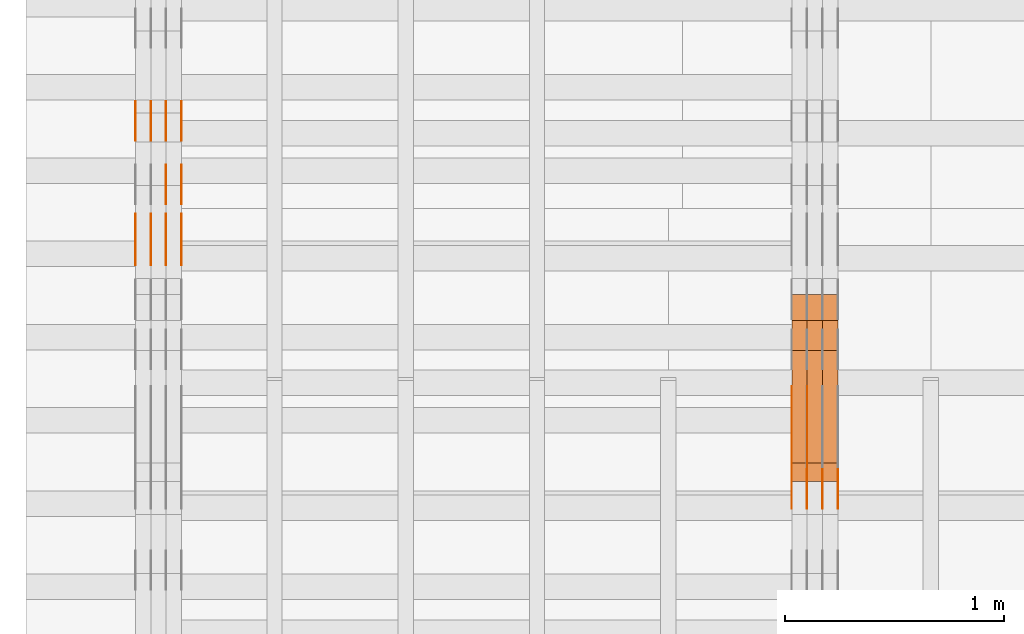
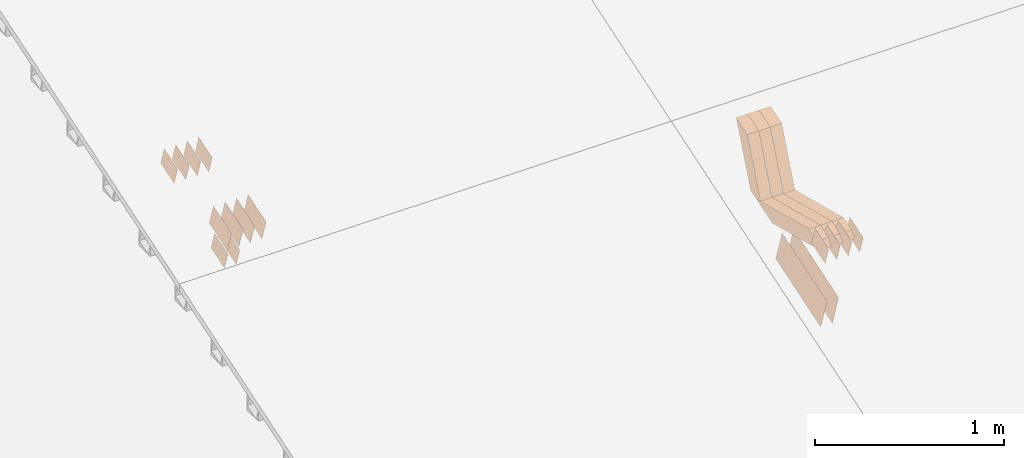
# One storey, part 46 of 385: 28 proxies.
"""IFC2X3 building model written with IfcOpenShell, lengths in millimetres."""

from ifc_helpers import new_model, entity, si_unit, converted_unit, derived_unit, direction, frame, origin, place, context, subcontext, project, spatial, polyline, outline, extrude, source, transform, mapped, material, type_object, type_shapes, element, save


model = new_model("IFC2X3")

# Units and contexts
model_context = context("Model", 3, precision=0.01, world=origin(), true_north=direction((6.12303176911189e-17, 1.0)))
body_context = subcontext(model_context, "Body", "Model", "MODEL_VIEW")
ifc_project = project(units=[si_unit("LENGTHUNIT", "METRE", prefix="MILLI"), si_unit("AREAUNIT", "SQUARE_METRE"), si_unit("VOLUMEUNIT", "CUBIC_METRE"), converted_unit("PLANEANGLEUNIT", "DEGREE", entity("IfcRatioMeasure", 0.0174532925199433), si_unit("PLANEANGLEUNIT", "RADIAN"), dimensions=[0, 0, 0, 0, 0, 0, 0]), si_unit("MASSUNIT", "GRAM", prefix="KILO"), derived_unit("MASSDENSITYUNIT", [(si_unit("MASSUNIT", "GRAM", prefix="KILO"), 1), (si_unit("LENGTHUNIT", "METRE"), -3)]), si_unit("TIMEUNIT", "SECOND"), si_unit("FREQUENCYUNIT", "HERTZ"), si_unit("THERMODYNAMICTEMPERATUREUNIT", "DEGREE_CELSIUS"), derived_unit("THERMALTRANSMITTANCEUNIT", [(si_unit("MASSUNIT", "GRAM", prefix="KILO"), 1), (si_unit("THERMODYNAMICTEMPERATUREUNIT", "KELVIN"), -1), (si_unit("TIMEUNIT", "SECOND"), -3)]), derived_unit("VOLUMETRICFLOWRATEUNIT", [(si_unit("LENGTHUNIT", "METRE"), 3), (si_unit("TIMEUNIT", "SECOND"), -1)]), si_unit("ELECTRICCURRENTUNIT", "AMPERE"), si_unit("ELECTRICVOLTAGEUNIT", "VOLT"), si_unit("POWERUNIT", "WATT"), si_unit("FORCEUNIT", "NEWTON", prefix="KILO"), si_unit("ILLUMINANCEUNIT", "LUX"), si_unit("LUMINOUSFLUXUNIT", "LUMEN"), si_unit("LUMINOUSINTENSITYUNIT", "CANDELA"), derived_unit("USERDEFINED", [(si_unit("MASSUNIT", "GRAM", prefix="KILO"), -1), (si_unit("LENGTHUNIT", "METRE"), -2), (si_unit("TIMEUNIT", "SECOND"), 3), (si_unit("LUMINOUSFLUXUNIT", "LUMEN"), 1)]), derived_unit("LINEARVELOCITYUNIT", [(si_unit("LENGTHUNIT", "METRE"), 1), (si_unit("TIMEUNIT", "SECOND"), -1)]), si_unit("PRESSUREUNIT", "PASCAL"), derived_unit("USERDEFINED", [(si_unit("LENGTHUNIT", "METRE"), -2), (si_unit("MASSUNIT", "GRAM", prefix="KILO"), 1), (si_unit("TIMEUNIT", "SECOND"), -2)])], contexts=[model_context])

# Site, building, storey
site_placement = place(None, origin())
site = spatial("IfcSite", under=ifc_project, at=site_placement, CompositionType="ELEMENT")
building_placement = place(site_placement, origin())
building = spatial("IfcBuilding", under=site, at=building_placement, CompositionType="ELEMENT")
storey_placement = place(building_placement, origin())
storey = spatial("IfcBuildingStorey", under=building, at=storey_placement, Name="Default", CompositionType="ELEMENT", Elevation=0.0)

# Proxies
ifc_material_1 = material(Name="IfcSurfaceStyle #73920")
building_element_proxy_type_1 = type_object("IfcBuildingElementProxyType", PredefinedType="NOTDEFINED", material=ifc_material_1)
shared_shape_1 = source(origin(), body_context, "Body", "SweptSolid", [
    extrude(outline(polyline([(-249.999749056184, -108.000229288163), (249.999396050782, -108.000229288163), (249.999749056184, 108.000229288163), (-249.999396050782, 108.000229288163), (-249.999749056184, -108.000229288163)])), frame((249.999841104007, 108.000229288163, 0.0), z_axis=(0.0, 0.0, 1.0), x_axis=(-1.0, 0.0, 0.0)), (0.0, 0.0, 1.0), 1.29999999999997),
])
type_shapes(building_element_proxy_type_1, [shared_shape_1])
proxy_1_placement = place(building_placement, frame((3246.29999999999, 7917.13457673635, 1720.66532252899), z_axis=(-1.0, 0.0, 0.0), x_axis=(0.0, 0.951056516295124, 0.309016994375039)))
element("IfcBuildingElementProxy", 1, at=proxy_1_placement, inside=storey, type_object=building_element_proxy_type_1, material=ifc_material_1, context=body_context, shape_type="MappedRepresentation", body=[
    mapped(shared_shape_1, transform((0.0, 0.0, 0.0), scale=1.0)),
])
ifc_material_2 = material(Name="IfcSurfaceStyle #73863")
building_element_proxy_type_2 = type_object("IfcBuildingElementProxyType", PredefinedType="NOTDEFINED", material=ifc_material_2)
shared_shape_2 = source(origin(), body_context, "Body", "SweptSolid", [
    extrude(outline(polyline([(-249.999749056184, -108.000229288163), (249.999396050782, -108.000229288163), (249.999749056184, 108.000229288163), (-249.999396050782, 108.000229288163), (-249.999749056184, -108.000229288163)])), frame((249.999841104007, 108.000229288163, 0.0), z_axis=(0.0, 0.0, 1.0), x_axis=(-1.0, 0.0, 0.0)), (0.0, 0.0, 1.0), 1.29999999999997),
])
type_shapes(building_element_proxy_type_2, [shared_shape_2])
proxy_2_placement = place(building_placement, frame((3175.0, 7917.13457673635, 1720.66532252899), z_axis=(-1.0, 0.0, 0.0), x_axis=(0.0, 0.951056516295124, 0.309016994375039)))
element("IfcBuildingElementProxy", 2, at=proxy_2_placement, inside=storey, type_object=building_element_proxy_type_2, material=ifc_material_2, context=body_context, shape_type="MappedRepresentation", body=[
    mapped(shared_shape_2, transform((0.0, 0.0, 0.0), scale=1.0)),
])
ifc_material_3 = material(Name="IfcSurfaceStyle #60468")
building_element_proxy_type_3 = type_object("IfcBuildingElementProxyType", PredefinedType="NOTDEFINED", material=ifc_material_3)
shared_shape_3 = source(origin(), body_context, "Body", "SweptSolid", [
    extrude(outline(polyline([(-74.9998754286253, -60.0000016373506), (74.9998605591091, -60.0000016373506), (74.9998754286234, 60.0000016373506), (-74.9998605591072, 60.0000016373506), (-74.9998754286253, -60.0000016373506)])), frame((75.0007355357002, 60.0002637031812, 0.0), z_axis=(0.0, 0.0, 1.0), x_axis=(-1.0, 0.0, 0.0)), (0.0, 0.0, 1.0), 1.3),
])
type_shapes(building_element_proxy_type_3, [shared_shape_3])
proxy_3_placement = place(building_placement, frame((3386.29999999999, 7899.79204652808, 2069.58672486412), z_axis=(-1.0, 0.0, 0.0), x_axis=(0.0, 0.951056516295154, 0.309016994374948)))
element("IfcBuildingElementProxy", 3, at=proxy_3_placement, inside=storey, type_object=building_element_proxy_type_3, material=ifc_material_3, context=body_context, shape_type="MappedRepresentation", body=[
    mapped(shared_shape_3, transform((0.0, 0.0, 0.0), scale=1.0)),
])
ifc_material_4 = material(Name="IfcSurfaceStyle #60411")
building_element_proxy_type_4 = type_object("IfcBuildingElementProxyType", PredefinedType="NOTDEFINED", material=ifc_material_4)
shared_shape_4 = source(origin(), body_context, "Body", "SweptSolid", [
    extrude(outline(polyline([(-74.9998754286253, -60.0000016373506), (74.9998605591091, -60.0000016373506), (74.9998754286234, 60.0000016373506), (-74.9998605591072, 60.0000016373506), (-74.9998754286253, -60.0000016373506)])), frame((75.0007355357002, 60.0002637031812, 0.0), z_axis=(0.0, 0.0, 1.0), x_axis=(-1.0, 0.0, 0.0)), (0.0, 0.0, 1.0), 1.3),
])
type_shapes(building_element_proxy_type_4, [shared_shape_4])
proxy_4_placement = place(building_placement, frame((3315.0, 7899.79204652808, 2069.58672486412), z_axis=(-1.0, 0.0, 0.0), x_axis=(0.0, 0.951056516295154, 0.309016994374948)))
element("IfcBuildingElementProxy", 4, at=proxy_4_placement, inside=storey, type_object=building_element_proxy_type_4, material=ifc_material_4, context=body_context, shape_type="MappedRepresentation", body=[
    mapped(shared_shape_4, transform((0.0, 0.0, 0.0), scale=1.0)),
])
ifc_material_5 = material(Name="IfcSurfaceStyle #60354")
building_element_proxy_type_5 = type_object("IfcBuildingElementProxyType", PredefinedType="NOTDEFINED", material=ifc_material_5)
shared_shape_5 = source(origin(), body_context, "Body", "SweptSolid", [
    extrude(outline(polyline([(-74.9998754286253, -60.0000016373506), (74.9998605591091, -60.0000016373506), (74.9998754286234, 60.0000016373506), (-74.9998605591072, 60.0000016373506), (-74.9998754286253, -60.0000016373506)])), frame((75.0007355357002, 60.0002637031812, 0.0), z_axis=(0.0, 0.0, 1.0), x_axis=(-1.0, 0.0, 0.0)), (0.0, 0.0, 1.0), 1.3),
])
type_shapes(building_element_proxy_type_5, [shared_shape_5])
proxy_5_placement = place(building_placement, frame((3316.29999999999, 7899.79204652808, 2069.58672486412), z_axis=(-1.0, 0.0, 0.0), x_axis=(0.0, 0.951056516295154, 0.309016994374948)))
element("IfcBuildingElementProxy", 5, at=proxy_5_placement, inside=storey, type_object=building_element_proxy_type_5, material=ifc_material_5, context=body_context, shape_type="MappedRepresentation", body=[
    mapped(shared_shape_5, transform((0.0, 0.0, 0.0), scale=1.0)),
])
ifc_material_6 = material(Name="IfcSurfaceStyle #60297")
building_element_proxy_type_6 = type_object("IfcBuildingElementProxyType", PredefinedType="NOTDEFINED", material=ifc_material_6)
shared_shape_6 = source(origin(), body_context, "Body", "SweptSolid", [
    extrude(outline(polyline([(-74.9998754286253, -60.0000016373506), (74.9998605591091, -60.0000016373506), (74.9998754286234, 60.0000016373506), (-74.9998605591072, 60.0000016373506), (-74.9998754286253, -60.0000016373506)])), frame((75.0007355357002, 60.0002637031812, 0.0), z_axis=(0.0, 0.0, 1.0), x_axis=(-1.0, 0.0, 0.0)), (0.0, 0.0, 1.0), 1.29999999999999),
])
type_shapes(building_element_proxy_type_6, [shared_shape_6])
proxy_6_placement = place(building_placement, frame((3245.0, 7899.79204652808, 2069.58672486412), z_axis=(-1.0, 0.0, 0.0), x_axis=(0.0, 0.951056516295154, 0.309016994374948)))
element("IfcBuildingElementProxy", 6, at=proxy_6_placement, inside=storey, type_object=building_element_proxy_type_6, material=ifc_material_6, context=body_context, shape_type="MappedRepresentation", body=[
    mapped(shared_shape_6, transform((0.0, 0.0, 0.0), scale=1.0)),
])
ifc_material_7 = material(Name="IfcSurfaceStyle #60240")
building_element_proxy_type_7 = type_object("IfcBuildingElementProxyType", PredefinedType="NOTDEFINED", material=ifc_material_7)
shared_shape_7 = source(origin(), body_context, "Body", "SweptSolid", [
    extrude(outline(polyline([(-74.9998754286253, -60.0000016373506), (74.9998605591091, -60.0000016373506), (74.9998754286234, 60.0000016373506), (-74.9998605591072, 60.0000016373506), (-74.9998754286253, -60.0000016373506)])), frame((75.0007355357002, 60.0002637031812, 0.0), z_axis=(0.0, 0.0, 1.0), x_axis=(-1.0, 0.0, 0.0)), (0.0, 0.0, 1.0), 1.29999999999999),
])
type_shapes(building_element_proxy_type_7, [shared_shape_7])
proxy_7_placement = place(building_placement, frame((3246.29999999999, 7899.79204652808, 2069.58672486412), z_axis=(-1.0, 0.0, 0.0), x_axis=(0.0, 0.951056516295154, 0.309016994374948)))
element("IfcBuildingElementProxy", 7, at=proxy_7_placement, inside=storey, type_object=building_element_proxy_type_7, material=ifc_material_7, context=body_context, shape_type="MappedRepresentation", body=[
    mapped(shared_shape_7, transform((0.0, 0.0, 0.0), scale=1.0)),
])
ifc_material_8 = material(Name="IfcSurfaceStyle #60183")
building_element_proxy_type_8 = type_object("IfcBuildingElementProxyType", PredefinedType="NOTDEFINED", material=ifc_material_8)
shared_shape_8 = source(origin(), body_context, "Body", "SweptSolid", [
    extrude(outline(polyline([(-74.9998754286253, -60.0000016373506), (74.9998605591091, -60.0000016373506), (74.9998754286234, 60.0000016373506), (-74.9998605591072, 60.0000016373506), (-74.9998754286253, -60.0000016373506)])), frame((75.0007355357002, 60.0002637031812, 0.0), z_axis=(0.0, 0.0, 1.0), x_axis=(-1.0, 0.0, 0.0)), (0.0, 0.0, 1.0), 1.29999999999999),
])
type_shapes(building_element_proxy_type_8, [shared_shape_8])
proxy_8_placement = place(building_placement, frame((3175.0, 7899.79204652808, 2069.58672486412), z_axis=(-1.0, 0.0, 0.0), x_axis=(0.0, 0.951056516295154, 0.309016994374948)))
element("IfcBuildingElementProxy", 8, at=proxy_8_placement, inside=storey, type_object=building_element_proxy_type_8, material=ifc_material_8, context=body_context, shape_type="MappedRepresentation", body=[
    mapped(shared_shape_8, transform((0.0, 0.0, 0.0), scale=1.0)),
])
ifc_material_9 = material(Name="IfcSurfaceStyle #48084")
building_element_proxy_type_9 = type_object("IfcBuildingElementProxyType", Name="T1-W45 48082", PredefinedType="NOTDEFINED", material=ifc_material_9)
shared_shape_9 = source(origin(), body_context, "Body", "SweptSolid", [
    extrude(outline(polyline([(-275.953018340717, -47.500197738425), (128.971267956636, -47.5001977384251), (168.669977842085, -0.000132525443043008), (174.867371111815, 47.5002640011466), (-196.55559856982, 47.5002640011466), (-275.953018340717, -47.500197738425)])), frame((174.867371111815, 47.5002640011466, 0.0), z_axis=(0.0, 0.0, 1.0), x_axis=(-1.0, 0.0, 0.0)), (0.0, 0.0, 1.0), 70.0),
])
type_shapes(building_element_proxy_type_9, [shared_shape_9])
proxy_9_placement = place(building_placement, frame((3385.0, 8621.494140625, 1941.33422851563), z_axis=(-1.0, 0.0, 0.0), x_axis=(0.0, 0.372787901688292, 0.927916580493549)))
element("IfcBuildingElementProxy", 9, at=proxy_9_placement, inside=storey, type_object=building_element_proxy_type_9, material=ifc_material_9, Name="T1-W45", context=body_context, shape_type="MappedRepresentation", body=[
    mapped(shared_shape_9, transform((0.0, 0.0, 0.0), scale=1.0)),
])
ifc_material_10 = material(Name="IfcSurfaceStyle #48018")
building_element_proxy_type_10 = type_object("IfcBuildingElementProxyType", Name="T1-W45 48016", PredefinedType="NOTDEFINED", material=ifc_material_10)
shared_shape_10 = source(origin(), body_context, "Body", "SweptSolid", [
    extrude(outline(polyline([(-275.953018340717, -47.500197738425), (128.971267956636, -47.5001977384251), (168.669977842085, -0.000132525443043008), (174.867371111815, 47.5002640011466), (-196.55559856982, 47.5002640011466), (-275.953018340717, -47.500197738425)])), frame((174.867371111815, 47.5002640011466, 0.0), z_axis=(0.0, 0.0, 1.0), x_axis=(-1.0, 0.0, 0.0)), (0.0, 0.0, 1.0), 70.0),
])
type_shapes(building_element_proxy_type_10, [shared_shape_10])
proxy_10_placement = place(building_placement, frame((3315.0, 8621.494140625, 1941.33422851563), z_axis=(-1.0, 0.0, 0.0), x_axis=(0.0, 0.372787901688292, 0.927916580493549)))
element("IfcBuildingElementProxy", 10, at=proxy_10_placement, inside=storey, type_object=building_element_proxy_type_10, material=ifc_material_10, Name="T1-W45", context=body_context, shape_type="MappedRepresentation", body=[
    mapped(shared_shape_10, transform((0.0, 0.0, 0.0), scale=1.0)),
])
ifc_material_11 = material(Name="IfcSurfaceStyle #47952")
building_element_proxy_type_11 = type_object("IfcBuildingElementProxyType", Name="T1-W45 47950", PredefinedType="NOTDEFINED", material=ifc_material_11)
shared_shape_11 = source(origin(), body_context, "Body", "SweptSolid", [
    extrude(outline(polyline([(-275.953018340717, -47.500197738425), (128.971267956636, -47.5001977384251), (168.669977842085, -0.000132525443043008), (174.867371111815, 47.5002640011466), (-196.55559856982, 47.5002640011466), (-275.953018340717, -47.500197738425)])), frame((174.867371111815, 47.5002640011466, 0.0), z_axis=(0.0, 0.0, 1.0), x_axis=(-1.0, 0.0, 0.0)), (0.0, 0.0, 1.0), 70.0),
])
type_shapes(building_element_proxy_type_11, [shared_shape_11])
proxy_11_placement = place(building_placement, frame((3245.0, 8621.494140625, 1941.33422851563), z_axis=(-1.0, 0.0, 0.0), x_axis=(0.0, 0.372787901688292, 0.927916580493549)))
element("IfcBuildingElementProxy", 11, at=proxy_11_placement, inside=storey, type_object=building_element_proxy_type_11, material=ifc_material_11, Name="T1-W45", context=body_context, shape_type="MappedRepresentation", body=[
    mapped(shared_shape_11, transform((0.0, 0.0, 0.0), scale=1.0)),
])
ifc_material_12 = material(Name="IfcSurfaceStyle #47688")
building_element_proxy_type_12 = type_object("IfcBuildingElementProxyType", Name="T1-W11 47686", PredefinedType="NOTDEFINED", material=ifc_material_12)
shared_shape_12 = source(origin(), body_context, "Body", "SweptSolid", [
    extrude(outline(polyline([(-261.366417792209, -47.5000378467523), (260.949520182121, -47.5000378467523), (242.928845159301, -7.41559889341215e-06), (168.237407166939, 47.5000415545517), (-410.749354716152, 47.5000415545517), (-261.366417792209, -47.5000378467523)])), frame((260.949520182121, 47.5000415545517, 0.0), z_axis=(0.0, 0.0, 1.0), x_axis=(-1.0, 0.0, 0.0)), (0.0, 0.0, 1.0), 70.0),
])
type_shapes(building_element_proxy_type_12, [shared_shape_12])
proxy_12_placement = place(building_placement, frame((3385.0, 8017.44318793234, 2097.03832883996), z_axis=(-1.0, 0.0, 0.0), x_axis=(0.0, 0.968347201599873, -0.249607085543851)))
element("IfcBuildingElementProxy", 12, at=proxy_12_placement, inside=storey, type_object=building_element_proxy_type_12, material=ifc_material_12, Name="T1-W11", context=body_context, shape_type="MappedRepresentation", body=[
    mapped(shared_shape_12, transform((0.0, 0.0, 0.0), scale=1.0)),
])
ifc_material_13 = material(Name="IfcSurfaceStyle #47622")
building_element_proxy_type_13 = type_object("IfcBuildingElementProxyType", Name="T1-W11 47620", PredefinedType="NOTDEFINED", material=ifc_material_13)
shared_shape_13 = source(origin(), body_context, "Body", "SweptSolid", [
    extrude(outline(polyline([(-261.366417792209, -47.5000378467523), (260.949520182121, -47.5000378467523), (242.928845159301, -7.41559889341215e-06), (168.237407166939, 47.5000415545517), (-410.749354716152, 47.5000415545517), (-261.366417792209, -47.5000378467523)])), frame((260.949520182121, 47.5000415545517, 0.0), z_axis=(0.0, 0.0, 1.0), x_axis=(-1.0, 0.0, 0.0)), (0.0, 0.0, 1.0), 70.0),
])
type_shapes(building_element_proxy_type_13, [shared_shape_13])
proxy_13_placement = place(building_placement, frame((3315.0, 8017.44318793234, 2097.03832883996), z_axis=(-1.0, 0.0, 0.0), x_axis=(0.0, 0.968347201599873, -0.249607085543851)))
element("IfcBuildingElementProxy", 13, at=proxy_13_placement, inside=storey, type_object=building_element_proxy_type_13, material=ifc_material_13, Name="T1-W11", context=body_context, shape_type="MappedRepresentation", body=[
    mapped(shared_shape_13, transform((0.0, 0.0, 0.0), scale=1.0)),
])
ifc_material_14 = material(Name="IfcSurfaceStyle #47556")
building_element_proxy_type_14 = type_object("IfcBuildingElementProxyType", Name="T1-W11 47554", PredefinedType="NOTDEFINED", material=ifc_material_14)
shared_shape_14 = source(origin(), body_context, "Body", "SweptSolid", [
    extrude(outline(polyline([(-261.366417792209, -47.5000378467523), (260.949520182121, -47.5000378467523), (242.928845159301, -7.41559889341215e-06), (168.237407166939, 47.5000415545517), (-410.749354716152, 47.5000415545517), (-261.366417792209, -47.5000378467523)])), frame((260.949520182121, 47.5000415545517, 0.0), z_axis=(0.0, 0.0, 1.0), x_axis=(-1.0, 0.0, 0.0)), (0.0, 0.0, 1.0), 70.0),
])
type_shapes(building_element_proxy_type_14, [shared_shape_14])
proxy_14_placement = place(building_placement, frame((3245.0, 8017.44318793234, 2097.03832883996), z_axis=(-1.0, 0.0, 0.0), x_axis=(0.0, 0.968347201599873, -0.249607085543851)))
element("IfcBuildingElementProxy", 14, at=proxy_14_placement, inside=storey, type_object=building_element_proxy_type_14, material=ifc_material_14, Name="T1-W11", context=body_context, shape_type="MappedRepresentation", body=[
    mapped(shared_shape_14, transform((0.0, 0.0, 0.0), scale=1.0)),
])
ifc_material_15 = material(Name="IfcSurfaceStyle #39374")
building_element_proxy_type_15 = type_object("IfcBuildingElementProxyType", PredefinedType="NOTDEFINED", material=ifc_material_15)
shared_shape_15 = source(origin(), body_context, "Body", "SweptSolid", [
    extrude(outline(polyline([(-99.999644645517, -72.0000317581407), (100.000028485991, -72.0000317581407), (99.999644645517, 72.0000317581407), (-100.000028485991, 72.0000317581407), (-99.999644645517, -72.0000317581407)])), frame((100.000028485991, 72.0000317581407, 0.0), z_axis=(0.0, 0.0, 1.0), x_axis=(-1.0, 0.0, 0.0)), (0.0, 0.0, 1.0), 1.3),
])
type_shapes(building_element_proxy_type_15, [shared_shape_15])
proxy_15_placement = place(building_placement, frame((386.299999999986, 9012.6304394324, 2546.30522609783), z_axis=(-1.0, 0.0, 0.0), x_axis=(0.0, 0.951056516295154, 0.309016994374948)))
element("IfcBuildingElementProxy", 15, at=proxy_15_placement, inside=storey, type_object=building_element_proxy_type_15, material=ifc_material_15, context=body_context, shape_type="MappedRepresentation", body=[
    mapped(shared_shape_15, transform((0.0, 0.0, 0.0), scale=1.0)),
])
ifc_material_16 = material(Name="IfcSurfaceStyle #39317")
building_element_proxy_type_16 = type_object("IfcBuildingElementProxyType", PredefinedType="NOTDEFINED", material=ifc_material_16)
shared_shape_16 = source(origin(), body_context, "Body", "SweptSolid", [
    extrude(outline(polyline([(-99.999644645517, -72.0000317581407), (100.000028485991, -72.0000317581407), (99.999644645517, 72.0000317581407), (-100.000028485991, 72.0000317581407), (-99.999644645517, -72.0000317581407)])), frame((100.000028485991, 72.0000317581407, 0.0), z_axis=(0.0, 0.0, 1.0), x_axis=(-1.0, 0.0, 0.0)), (0.0, 0.0, 1.0), 1.3),
])
type_shapes(building_element_proxy_type_16, [shared_shape_16])
proxy_16_placement = place(building_placement, frame((315.0, 9012.6304394324, 2546.30522609783), z_axis=(-1.0, 0.0, 0.0), x_axis=(0.0, 0.951056516295154, 0.309016994374948)))
element("IfcBuildingElementProxy", 16, at=proxy_16_placement, inside=storey, type_object=building_element_proxy_type_16, material=ifc_material_16, context=body_context, shape_type="MappedRepresentation", body=[
    mapped(shared_shape_16, transform((0.0, 0.0, 0.0), scale=1.0)),
])
ifc_material_17 = material(Name="IfcSurfaceStyle #39260")
building_element_proxy_type_17 = type_object("IfcBuildingElementProxyType", PredefinedType="NOTDEFINED", material=ifc_material_17)
shared_shape_17 = source(origin(), body_context, "Body", "SweptSolid", [
    extrude(outline(polyline([(-99.999644645517, -72.0000317581407), (100.000028485991, -72.0000317581407), (99.999644645517, 72.0000317581407), (-100.000028485991, 72.0000317581407), (-99.999644645517, -72.0000317581407)])), frame((100.000028485991, 72.0000317581407, 0.0), z_axis=(0.0, 0.0, 1.0), x_axis=(-1.0, 0.0, 0.0)), (0.0, 0.0, 1.0), 1.3),
])
type_shapes(building_element_proxy_type_17, [shared_shape_17])
proxy_17_placement = place(building_placement, frame((316.299999999986, 9012.6304394324, 2546.30522609783), z_axis=(-1.0, 0.0, 0.0), x_axis=(0.0, 0.951056516295154, 0.309016994374948)))
element("IfcBuildingElementProxy", 17, at=proxy_17_placement, inside=storey, type_object=building_element_proxy_type_17, material=ifc_material_17, context=body_context, shape_type="MappedRepresentation", body=[
    mapped(shared_shape_17, transform((0.0, 0.0, 0.0), scale=1.0)),
])
ifc_material_18 = material(Name="IfcSurfaceStyle #39203")
building_element_proxy_type_18 = type_object("IfcBuildingElementProxyType", PredefinedType="NOTDEFINED", material=ifc_material_18)
shared_shape_18 = source(origin(), body_context, "Body", "SweptSolid", [
    extrude(outline(polyline([(-99.999644645517, -72.0000317581407), (100.000028485991, -72.0000317581407), (99.999644645517, 72.0000317581407), (-100.000028485991, 72.0000317581407), (-99.999644645517, -72.0000317581407)])), frame((100.000028485991, 72.0000317581407, 0.0), z_axis=(0.0, 0.0, 1.0), x_axis=(-1.0, 0.0, 0.0)), (0.0, 0.0, 1.0), 1.29999999999998),
])
type_shapes(building_element_proxy_type_18, [shared_shape_18])
proxy_18_placement = place(building_placement, frame((245.0, 9012.6304394324, 2546.30522609783), z_axis=(-1.0, 0.0, 0.0), x_axis=(0.0, 0.951056516295154, 0.309016994374948)))
element("IfcBuildingElementProxy", 18, at=proxy_18_placement, inside=storey, type_object=building_element_proxy_type_18, material=ifc_material_18, context=body_context, shape_type="MappedRepresentation", body=[
    mapped(shared_shape_18, transform((0.0, 0.0, 0.0), scale=1.0)),
])
ifc_material_19 = material(Name="IfcSurfaceStyle #39146")
building_element_proxy_type_19 = type_object("IfcBuildingElementProxyType", PredefinedType="NOTDEFINED", material=ifc_material_19)
shared_shape_19 = source(origin(), body_context, "Body", "SweptSolid", [
    extrude(outline(polyline([(-99.999644645517, -72.0000317581407), (100.000028485991, -72.0000317581407), (99.999644645517, 72.0000317581407), (-100.000028485991, 72.0000317581407), (-99.999644645517, -72.0000317581407)])), frame((100.000028485991, 72.0000317581407, 0.0), z_axis=(0.0, 0.0, 1.0), x_axis=(-1.0, 0.0, 0.0)), (0.0, 0.0, 1.0), 1.29999999999998),
])
type_shapes(building_element_proxy_type_19, [shared_shape_19])
proxy_19_placement = place(building_placement, frame((246.299999999986, 9012.6304394324, 2546.30522609783), z_axis=(-1.0, 0.0, 0.0), x_axis=(0.0, 0.951056516295154, 0.309016994374948)))
element("IfcBuildingElementProxy", 19, at=proxy_19_placement, inside=storey, type_object=building_element_proxy_type_19, material=ifc_material_19, context=body_context, shape_type="MappedRepresentation", body=[
    mapped(shared_shape_19, transform((0.0, 0.0, 0.0), scale=1.0)),
])
ifc_material_20 = material(Name="IfcSurfaceStyle #39089")
building_element_proxy_type_20 = type_object("IfcBuildingElementProxyType", PredefinedType="NOTDEFINED", material=ifc_material_20)
shared_shape_20 = source(origin(), body_context, "Body", "SweptSolid", [
    extrude(outline(polyline([(-99.999644645517, -72.0000317581407), (100.000028485991, -72.0000317581407), (99.999644645517, 72.0000317581407), (-100.000028485991, 72.0000317581407), (-99.999644645517, -72.0000317581407)])), frame((100.000028485991, 72.0000317581407, 0.0), z_axis=(0.0, 0.0, 1.0), x_axis=(-1.0, 0.0, 0.0)), (0.0, 0.0, 1.0), 1.29999999999999),
])
type_shapes(building_element_proxy_type_20, [shared_shape_20])
proxy_20_placement = place(building_placement, frame((175.0, 9012.6304394324, 2546.30522609783), z_axis=(-1.0, 0.0, 0.0), x_axis=(0.0, 0.951056516295154, 0.309016994374948)))
element("IfcBuildingElementProxy", 20, at=proxy_20_placement, inside=storey, type_object=building_element_proxy_type_20, material=ifc_material_20, context=body_context, shape_type="MappedRepresentation", body=[
    mapped(shared_shape_20, transform((0.0, 0.0, 0.0), scale=1.0)),
])
ifc_material_21 = material(Name="IfcSurfaceStyle #39032")
building_element_proxy_type_21 = type_object("IfcBuildingElementProxyType", PredefinedType="NOTDEFINED", material=ifc_material_21)
shared_shape_21 = source(origin(), body_context, "Body", "SweptSolid", [
    extrude(outline(polyline([(-74.9998754286207, -60.0000016373506), (74.9998605591063, -60.0000016373506), (74.9998754286244, 60.0000016373506), (-74.9998605591099, 60.0000016373506), (-74.9998754286207, -60.0000016373506)])), frame((74.9998754286244, 60.0000016373506, 0.0), z_axis=(0.0, 0.0, 1.0), x_axis=(-1.0, 0.0, 0.0)), (0.0, 0.0, 1.0), 1.3),
])
type_shapes(building_element_proxy_type_21, [shared_shape_21])
proxy_21_placement = place(building_placement, frame((386.299999999986, 9580.89841427132, 2615.81135078741), z_axis=(-1.0, 0.0, 0.0), x_axis=(0.0, 0.951056516295154, 0.309016994374948)))
element("IfcBuildingElementProxy", 21, at=proxy_21_placement, inside=storey, type_object=building_element_proxy_type_21, material=ifc_material_21, context=body_context, shape_type="MappedRepresentation", body=[
    mapped(shared_shape_21, transform((0.0, 0.0, 0.0), scale=1.0)),
])
ifc_material_22 = material(Name="IfcSurfaceStyle #38975")
building_element_proxy_type_22 = type_object("IfcBuildingElementProxyType", PredefinedType="NOTDEFINED", material=ifc_material_22)
shared_shape_22 = source(origin(), body_context, "Body", "SweptSolid", [
    extrude(outline(polyline([(-74.9998754286207, -60.0000016373506), (74.9998605591063, -60.0000016373506), (74.9998754286244, 60.0000016373506), (-74.9998605591099, 60.0000016373506), (-74.9998754286207, -60.0000016373506)])), frame((74.9998754286244, 60.0000016373506, 0.0), z_axis=(0.0, 0.0, 1.0), x_axis=(-1.0, 0.0, 0.0)), (0.0, 0.0, 1.0), 1.3),
])
type_shapes(building_element_proxy_type_22, [shared_shape_22])
proxy_22_placement = place(building_placement, frame((315.0, 9580.89841427132, 2615.81135078741), z_axis=(-1.0, 0.0, 0.0), x_axis=(0.0, 0.951056516295154, 0.309016994374948)))
element("IfcBuildingElementProxy", 22, at=proxy_22_placement, inside=storey, type_object=building_element_proxy_type_22, material=ifc_material_22, context=body_context, shape_type="MappedRepresentation", body=[
    mapped(shared_shape_22, transform((0.0, 0.0, 0.0), scale=1.0)),
])
ifc_material_23 = material(Name="IfcSurfaceStyle #38918")
building_element_proxy_type_23 = type_object("IfcBuildingElementProxyType", PredefinedType="NOTDEFINED", material=ifc_material_23)
shared_shape_23 = source(origin(), body_context, "Body", "SweptSolid", [
    extrude(outline(polyline([(-74.9998754286207, -60.0000016373506), (74.9998605591063, -60.0000016373506), (74.9998754286244, 60.0000016373506), (-74.9998605591099, 60.0000016373506), (-74.9998754286207, -60.0000016373506)])), frame((74.9998754286244, 60.0000016373506, 0.0), z_axis=(0.0, 0.0, 1.0), x_axis=(-1.0, 0.0, 0.0)), (0.0, 0.0, 1.0), 1.3),
])
type_shapes(building_element_proxy_type_23, [shared_shape_23])
proxy_23_placement = place(building_placement, frame((316.299999999986, 9580.89841427132, 2615.81135078741), z_axis=(-1.0, 0.0, 0.0), x_axis=(0.0, 0.951056516295154, 0.309016994374948)))
element("IfcBuildingElementProxy", 23, at=proxy_23_placement, inside=storey, type_object=building_element_proxy_type_23, material=ifc_material_23, context=body_context, shape_type="MappedRepresentation", body=[
    mapped(shared_shape_23, transform((0.0, 0.0, 0.0), scale=1.0)),
])
ifc_material_24 = material(Name="IfcSurfaceStyle #38861")
building_element_proxy_type_24 = type_object("IfcBuildingElementProxyType", PredefinedType="NOTDEFINED", material=ifc_material_24)
shared_shape_24 = source(origin(), body_context, "Body", "SweptSolid", [
    extrude(outline(polyline([(-74.9998754286207, -60.0000016373506), (74.9998605591063, -60.0000016373506), (74.9998754286244, 60.0000016373506), (-74.9998605591099, 60.0000016373506), (-74.9998754286207, -60.0000016373506)])), frame((74.9998754286244, 60.0000016373506, 0.0), z_axis=(0.0, 0.0, 1.0), x_axis=(-1.0, 0.0, 0.0)), (0.0, 0.0, 1.0), 1.29999999999999),
])
type_shapes(building_element_proxy_type_24, [shared_shape_24])
proxy_24_placement = place(building_placement, frame((245.0, 9580.89841427132, 2615.81135078741), z_axis=(-1.0, 0.0, 0.0), x_axis=(0.0, 0.951056516295154, 0.309016994374948)))
element("IfcBuildingElementProxy", 24, at=proxy_24_placement, inside=storey, type_object=building_element_proxy_type_24, material=ifc_material_24, context=body_context, shape_type="MappedRepresentation", body=[
    mapped(shared_shape_24, transform((0.0, 0.0, 0.0), scale=1.0)),
])
ifc_material_25 = material(Name="IfcSurfaceStyle #38804")
building_element_proxy_type_25 = type_object("IfcBuildingElementProxyType", PredefinedType="NOTDEFINED", material=ifc_material_25)
shared_shape_25 = source(origin(), body_context, "Body", "SweptSolid", [
    extrude(outline(polyline([(-74.9998754286207, -60.0000016373506), (74.9998605591063, -60.0000016373506), (74.9998754286244, 60.0000016373506), (-74.9998605591099, 60.0000016373506), (-74.9998754286207, -60.0000016373506)])), frame((74.9998754286244, 60.0000016373506, 0.0), z_axis=(0.0, 0.0, 1.0), x_axis=(-1.0, 0.0, 0.0)), (0.0, 0.0, 1.0), 1.29999999999999),
])
type_shapes(building_element_proxy_type_25, [shared_shape_25])
proxy_25_placement = place(building_placement, frame((246.299999999986, 9580.89841427132, 2615.81135078741), z_axis=(-1.0, 0.0, 0.0), x_axis=(0.0, 0.951056516295154, 0.309016994374948)))
element("IfcBuildingElementProxy", 25, at=proxy_25_placement, inside=storey, type_object=building_element_proxy_type_25, material=ifc_material_25, context=body_context, shape_type="MappedRepresentation", body=[
    mapped(shared_shape_25, transform((0.0, 0.0, 0.0), scale=1.0)),
])
ifc_material_26 = material(Name="IfcSurfaceStyle #38747")
building_element_proxy_type_26 = type_object("IfcBuildingElementProxyType", PredefinedType="NOTDEFINED", material=ifc_material_26)
shared_shape_26 = source(origin(), body_context, "Body", "SweptSolid", [
    extrude(outline(polyline([(-74.9998754286207, -60.0000016373506), (74.9998605591063, -60.0000016373506), (74.9998754286244, 60.0000016373506), (-74.9998605591099, 60.0000016373506), (-74.9998754286207, -60.0000016373506)])), frame((74.9998754286244, 60.0000016373506, 0.0), z_axis=(0.0, 0.0, 1.0), x_axis=(-1.0, 0.0, 0.0)), (0.0, 0.0, 1.0), 1.29999999999999),
])
type_shapes(building_element_proxy_type_26, [shared_shape_26])
proxy_26_placement = place(building_placement, frame((175.0, 9580.89841427132, 2615.81135078741), z_axis=(-1.0, 0.0, 0.0), x_axis=(0.0, 0.951056516295154, 0.309016994374948)))
element("IfcBuildingElementProxy", 26, at=proxy_26_placement, inside=storey, type_object=building_element_proxy_type_26, material=ifc_material_26, context=body_context, shape_type="MappedRepresentation", body=[
    mapped(shared_shape_26, transform((0.0, 0.0, 0.0), scale=1.0)),
])
ifc_material_27 = material(Name="IfcSurfaceStyle #38006")
building_element_proxy_type_27 = type_object("IfcBuildingElementProxyType", PredefinedType="NOTDEFINED", material=ifc_material_27)
shared_shape_27 = source(origin(), body_context, "Body", "SweptSolid", [
    extrude(outline(polyline([(-75.0008041947458, -59.9996998629349), (75.0007893252423, -59.9996998629349), (75.0008041947458, 59.9996998629349), (-75.0007893252423, 59.9996998629349), (-75.0008041947458, -59.9996998629349)])), frame((75.0008041947458, 60.0002282421692, 0.0), z_axis=(0.0, 0.0, 1.0), x_axis=(-1.0, 0.0, 0.0)), (0.0, 0.0, 1.0), 1.3),
])
type_shapes(building_element_proxy_type_27, [shared_shape_27])
proxy_27_placement = place(building_placement, frame((386.299999999986, 9291.048828125, 2194.94482421875), z_axis=(-1.0, 0.0, 0.0), x_axis=(0.0, 0.951056516295124, 0.309016994375039)))
element("IfcBuildingElementProxy", 27, at=proxy_27_placement, inside=storey, type_object=building_element_proxy_type_27, material=ifc_material_27, context=body_context, shape_type="MappedRepresentation", body=[
    mapped(shared_shape_27, transform((0.0, 0.0, 0.0), scale=1.0)),
])
ifc_material_28 = material(Name="IfcSurfaceStyle #37949")
building_element_proxy_type_28 = type_object("IfcBuildingElementProxyType", PredefinedType="NOTDEFINED", material=ifc_material_28)
shared_shape_28 = source(origin(), body_context, "Body", "SweptSolid", [
    extrude(outline(polyline([(-75.0008041947458, -59.9996998629349), (75.0007893252423, -59.9996998629349), (75.0008041947458, 59.9996998629349), (-75.0007893252423, 59.9996998629349), (-75.0008041947458, -59.9996998629349)])), frame((75.0008041947458, 60.0002282421692, 0.0), z_axis=(0.0, 0.0, 1.0), x_axis=(-1.0, 0.0, 0.0)), (0.0, 0.0, 1.0), 1.3),
])
type_shapes(building_element_proxy_type_28, [shared_shape_28])
proxy_28_placement = place(building_placement, frame((315.0, 9291.048828125, 2194.94482421875), z_axis=(-1.0, 0.0, 0.0), x_axis=(0.0, 0.951056516295124, 0.309016994375039)))
element("IfcBuildingElementProxy", 28, at=proxy_28_placement, inside=storey, type_object=building_element_proxy_type_28, material=ifc_material_28, context=body_context, shape_type="MappedRepresentation", body=[
    mapped(shared_shape_28, transform((0.0, 0.0, 0.0), scale=1.0)),
])

save(model, "model.ifc")
